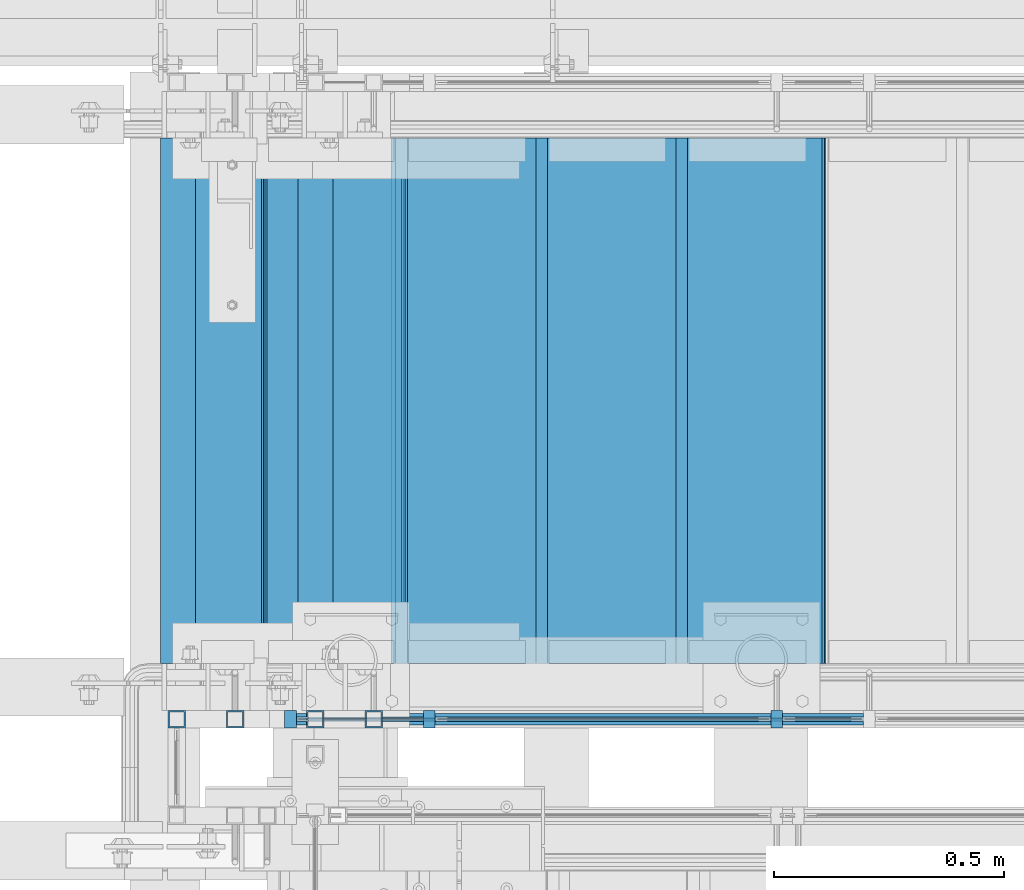
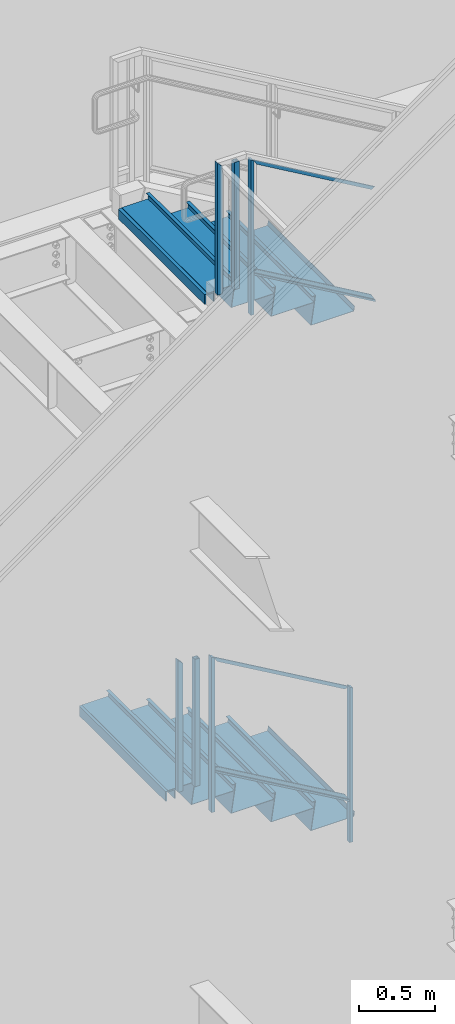
# One storey, part 791 of 1179: 15 beams, 9 members, 6 elements without a shape of their own.
"""IFC2X3 building model written with IfcOpenShell, lengths in millimetres."""

import ifcopenshell
import ifcopenshell.guid

model = None  # the IFC model being written
_history = None  # IfcOwnerHistory: only IFC2X3 demands one
_inside = {}  # id of a spatial element -> (the spatial element, [elements in it])
_under = {}  # id of a project, library or spatial element -> (it, [spatial elements below it])
_declared = {}  # id of a project -> (the project, [libraries it declares])
_typed = {}  # id of a type object -> (the type object, [elements of that type])
_made_of = {}  # id of a material, layer set ... -> (it, [elements and type objects made of it])


def new_model(schema):
    """Start an empty IFC model of exactly this schema.

    Asked for "IFC4X3", IfcOpenShell would pick the latest addendum, in which some entities
    have other attributes; the version numbers below select the first issue.
    IFC2X3 requires an IfcOwnerHistory on every rooted entity: one is made here for all.
    """
    global model, _history
    if schema == "IFC4X3":
        model = ifcopenshell.file(schema_version=(4, 3, 0, 0))
    else:
        model = ifcopenshell.file(schema=schema)
    _inside.clear()
    _under.clear()
    _declared.clear()
    _typed.clear()
    _made_of.clear()
    _history = None
    if model.schema == "IFC2X3":
        org = make("IfcOrganization", Name="unknown")
        user = make(
            "IfcPersonAndOrganization",
            ThePerson=make("IfcPerson", FamilyName="unknown"),
            TheOrganization=org,
        )
        app = make(
            "IfcApplication",
            ApplicationDeveloper=org,
            Version="unknown",
            ApplicationFullName="unknown",
            ApplicationIdentifier="unknown",
        )
        _history = make(
            "IfcOwnerHistory",
            OwningUser=user,
            OwningApplication=app,
            ChangeAction="ADDED",
            CreationDate=0,
        )
    return model


def make(cls, **values):
    """One entity of the class cls with the attributes given. An attribute that is None is left unset."""
    return model.create_entity(
        cls, **{name: value for name, value in values.items() if value is not None}
    )


def rooted(cls, **values):
    """An entity with a GlobalId (a new one), such as an element, a storey or a relation."""
    return make(cls, GlobalId=ifcopenshell.guid.new(), OwnerHistory=_history, **values)


def si_unit(unit_type, name, prefix=None):
    """IfcSIUnit, for example si_unit("LENGTHUNIT", "METRE", prefix="MILLI")."""
    return make("IfcSIUnit", UnitType=unit_type, Prefix=prefix, Name=name)


def assignment(units):
    """IfcUnitAssignment: the units of a project."""
    return None if units is None else make("IfcUnitAssignment", Units=units)


def point(xyz):
    """IfcCartesianPoint."""
    return None if xyz is None else make("IfcCartesianPoint", Coordinates=xyz)


def direction(xyz):
    """IfcDirection."""
    return None if xyz is None else make("IfcDirection", DirectionRatios=xyz)


def frame(location, z_axis=None, x_axis=None):
    """IfcAxis2Placement3D, a coordinate frame: its origin and axes. An axis left out is left unset."""
    return make(
        "IfcAxis2Placement3D",
        Location=point(location),
        Axis=direction(z_axis),
        RefDirection=direction(x_axis),
    )


def origin_with_axes():
    """The frame at (0, 0, 0) with the z axis (0, 0, 1) and the x axis (1, 0, 0) written out."""
    return frame((0.0, 0.0, 0.0), z_axis=(0.0, 0.0, 1.0), x_axis=(1.0, 0.0, 0.0))


def place(relative_to, where):
    """IfcLocalPlacement: puts the frame where relative to a parent placement (None: the world)."""
    return make(
        "IfcLocalPlacement", PlacementRelTo=relative_to, RelativePlacement=where
    )


def context(
    kind, dimensions, precision=None, world=None, true_north=None, identifier=None
):
    """IfcGeometricRepresentationContext, for example the 3D "Model" context."""
    return make(
        "IfcGeometricRepresentationContext",
        ContextIdentifier=identifier,
        ContextType=kind,
        CoordinateSpaceDimension=dimensions,
        Precision=precision,
        WorldCoordinateSystem=world,
        TrueNorth=true_north,
    )


def subcontext(parent, identifier, kind, view, scale=None):
    """IfcGeometricRepresentationSubContext, for example "Body" below "Model"."""
    return make(
        "IfcGeometricRepresentationSubContext",
        ContextIdentifier=identifier,
        ContextType=kind,
        ParentContext=parent,
        TargetScale=scale,
        TargetView=view,
    )


def project(units=None, contexts=None):
    """IfcProject with its units and contexts."""
    return rooted(
        "IfcProject",
        Name="project",
        RepresentationContexts=contexts,
        UnitsInContext=assignment(units),
    )


def spatial(cls, under=None, at=None, **own):
    """A site, building, storey or space (cls), placed at a placement, below another one or the project."""
    s = rooted(cls, ObjectPlacement=at, **own)
    if under is not None:
        _under.setdefault(under.id(), (under, []))[1].append(s)
    return s


def faces_of(points, faces, orient=None, outer=None):
    """IfcFace entities. A face is a list of loops; a loop is a list of indices into points, from 0.

    orient and outer hold one flag for each loop. By default every Orientation is true, the
    first loop of a face is its IfcFaceOuterBound and the others are IfcFaceBound.
    """
    made = []
    for i, loops in enumerate(faces):
        bounds = []
        for j, loop in enumerate(loops):
            is_outer = j == 0 if outer is None else outer[i][j]
            bounds.append(
                make(
                    "IfcFaceOuterBound" if is_outer else "IfcFaceBound",
                    Bound=make("IfcPolyLoop", Polygon=[points[k] for k in loop]),
                    Orientation=True if orient is None else orient[i][j],
                )
            )
        made.append(make("IfcFace", Bounds=bounds))
    return made


def faceted_brep(points, faces, orient=None, outer=None, voids=None):
    """IfcFacetedBrep: a solid bounded by flat faces; with voids (closed shells), ...WithVoids."""
    shared = [point(p) for p in points]
    hull = make("IfcClosedShell", CfsFaces=faces_of(shared, faces, orient, outer))
    if voids is None:
        return make("IfcFacetedBrep", Outer=hull)
    return make(
        "IfcFacetedBrepWithVoids",
        Outer=hull,
        Voids=[
            make(cls, CfsFaces=faces_of(shared, fs, o, b)) for cls, fs, o, b in voids
        ],
    )


def shape(context_of_items, identifier, shape_type, items):
    """IfcShapeRepresentation: the items that make up one representation, for example the "Body"."""
    return make(
        "IfcShapeRepresentation",
        ContextOfItems=context_of_items,
        RepresentationIdentifier=identifier,
        RepresentationType=shape_type,
        Items=items,
    )


def material(Name=None, Category=None):
    """IfcMaterial."""
    return make("IfcMaterial", Name=Name, Category=Category)


def made_of(thing, what):
    """Note that an element or type object is made of a material, layer set ...; save() writes the relation."""
    if what is not None:
        _made_of.setdefault(what.id(), (what, []))[1].append(thing)
    return thing


def type_object(cls, material=None, **own):
    """A type object (cls), such as IfcWallType, which elements share."""
    return made_of(rooted(cls, **own), material)


def element(
    cls,
    number,
    at=None,
    inside=None,
    cuts=None,
    type_object=None,
    material=None,
    context=None,
    identifier="Body",
    shape_type=None,
    held_by="IfcProductDefinitionShape",
    body=None,
    shapes=None,
    **own,
):
    """One element of the class cls, such as IfcWall. Its Tag is "e" and its number.

    at: its placement. inside: the storey or other place that contains it. cuts: it is an
    opening in that element (IfcRelVoidsElement). A single representation is given by context,
    identifier, shape_type and body (its items); several are given by shapes. held_by: the class
    of the entity that holds the representations. save() writes the other relations.
    """
    e = rooted(cls, Tag="e%d" % number, ObjectPlacement=at, **own)
    if body is not None:
        shapes = [shape(context, identifier, shape_type, body)]
    if shapes is not None:
        e.Representation = make(held_by, Representations=shapes)
    if inside is not None:
        _inside.setdefault(inside.id(), (inside, []))[1].append(e)
    if cuts is not None:
        rooted(
            "IfcRelVoidsElement", RelatingBuildingElement=cuts, RelatedOpeningElement=e
        )
    if type_object is not None:
        _typed.setdefault(type_object.id(), (type_object, []))[1].append(e)
    return made_of(e, material)


def aggregate(whole, parts):
    """IfcRelAggregates: a whole, such as a stair, and the parts it consists of."""
    return rooted("IfcRelAggregates", RelatingObject=whole, RelatedObjects=parts)


def save(model, path):
    """Write the relations noted so far, then the file.

    IfcRelAggregates (storeys below a building ...), IfcRelContainedInSpatialStructure (elements
    in a storey), IfcRelDefinesByType, IfcRelAssociatesMaterial and IfcRelDeclares: one each for
    every whole, place, type object, material and project.
    """
    for whole, parts in _under.values():
        aggregate(whole, parts)
    for where, things in _inside.values():
        rooted(
            "IfcRelContainedInSpatialStructure",
            RelatedElements=things,
            RelatingStructure=where,
        )
    for kind, things in _typed.values():
        rooted("IfcRelDefinesByType", RelatedObjects=things, RelatingType=kind)
    for what, things in _made_of.values():
        rooted("IfcRelAssociatesMaterial", RelatedObjects=things, RelatingMaterial=what)
    for by, libraries in _declared.values():
        rooted("IfcRelDeclares", RelatingContext=by, RelatedDefinitions=libraries)
    model.write(path)


model = new_model("IFC2X3")

# Units and contexts
model_context = context("Model", 3, precision=1e-05, world=origin_with_axes())
body_context = subcontext(model_context, "Body", "Model", "MODEL_VIEW")
ifc_project = project(units=[si_unit("LENGTHUNIT", "METRE", prefix="MILLI"), si_unit("AREAUNIT", "SQUARE_METRE"), si_unit("VOLUMEUNIT", "CUBIC_METRE"), si_unit("MASSUNIT", "GRAM", prefix="KILO"), si_unit("TIMEUNIT", "SECOND"), si_unit("PLANEANGLEUNIT", "RADIAN"), si_unit("SOLIDANGLEUNIT", "STERADIAN"), si_unit("THERMODYNAMICTEMPERATUREUNIT", "DEGREE_CELSIUS"), si_unit("LUMINOUSINTENSITYUNIT", "LUMEN")], contexts=[model_context])

# Site, building, storey
site_placement = place(None, origin_with_axes())
site = spatial("IfcSite", under=ifc_project, at=site_placement, CompositionType="ELEMENT")
building_placement = place(site_placement, origin_with_axes())
building = spatial("IfcBuilding", under=site, at=building_placement, Name="Undefined", CompositionType="ELEMENT")
storey_placement = place(building_placement, origin_with_axes())
storey = spatial("IfcBuildingStorey", under=building, at=storey_placement, Name="Undefined", CompositionType="ELEMENT", Elevation=0.0)

# Assembly, member
assembly_1_placement = place(storey_placement, origin_with_axes())
assembly_1 = element("IfcElementAssembly", 1, at=assembly_1_placement, inside=storey, Name="GUARDRAIL", AssemblyPlace="NOTDEFINED", PredefinedType="RIGID_FRAME")
ifc_material_1 = material(Name="STEEL/A36")
member_type_1 = type_object("IfcMemberType", PredefinedType="NOTDEFINED")
member_1_placement = place(assembly_1_placement, frame((20608.9249611471, 39681.150000778, 3388.43033673067), z_axis=(0.0, -1.0, 0.0), x_axis=(0.0, 0.0, 1.0)))
member_1 = element("IfcMember", 2, at=member_1_placement, type_object=member_type_1, material=ifc_material_1, Name="POST", context=body_context, shape_type="Brep", body=[
    faceted_brep([(0.0, 12.7000000000007, -19.0500000000029), (0.0, 12.7000000000007, 19.0500000000029), (1257.59245944594, 12.7000000000007, 19.0500000000029), (1257.59245944594, 12.7000000000007, -19.0500000000029), (0.0, -12.7000000000007, 19.0500000000029), (1242.88603583053, -12.7000000000007, 19.0500000000029), (0.0, -12.7000000000007, -19.0500000000029), (1242.88603583053, -12.7000000000007, -19.0500000000029)], [[[0, 1, 2, 3]], [[1, 4, 5, 2]], [[4, 6, 7, 5]], [[6, 0, 3, 7]], [[5, 7, 3, 2]], [[6, 4, 1, 0]]]),
])

assembly_2_placement = place(storey_placement, origin_with_axes())
assembly_2 = element("IfcElementAssembly", 3, at=assembly_2_placement, inside=storey, Name="GUARDRAIL", AssemblyPlace="NOTDEFINED", PredefinedType="RIGID_FRAME")
member_2_placement = place(assembly_2_placement, frame((19853.2749999269, 39681.1500007796, 7913.42903654841), z_axis=(0.0, -1.0, 0.0), x_axis=(0.0, 0.0, 1.0)))
member_2 = element("IfcMember", 4, at=member_2_placement, type_object=member_type_1, material=ifc_material_1, Name="POST", context=body_context, shape_type="Brep", body=[
    faceted_brep([(0.0, 12.7000000000007, -19.0500000000029), (0.0, 12.7000000000007, 19.0500000000029), (1257.9937907086, 12.7000000000007, 19.0500000000029), (1257.9937907086, 12.7000000000007, -19.0500000000029), (0.0, -12.7000000000007, 19.0500000000029), (1243.17712405909, -12.7000000000007, 19.0500000000029), (0.0, -12.7000000000007, -19.0500000000029), (1243.17712405909, -12.7000000000007, -19.0500000000029)], [[[0, 1, 2, 3]], [[1, 4, 5, 2]], [[4, 6, 7, 5]], [[6, 0, 3, 7]], [[5, 7, 3, 2]], [[6, 4, 1, 0]]]),
])

# Member
member_3_placement = place(assembly_1_placement, frame((19551.6499976895, 39681.1500007814, 4000.58519856457), z_axis=(0.0, -1.0, 0.0), x_axis=(0.0, 0.0, 1.0)))
member_3 = element("IfcMember", 5, at=member_3_placement, type_object=member_type_1, material=ifc_material_1, Name="POST", context=body_context, shape_type="Brep", body=[
    faceted_brep([(1242.88603583053, -12.7000000000007, 19.0500000000029), (1242.88603583053, -12.7000000000007, -19.0500000000029), (1257.59245944594, 12.7000000000007, -19.0500000000029), (1257.59245944594, 12.7000000000007, 19.0500000000029), (0.0, -12.7000000000007, -19.0500000000029), (0.0, -12.7000000000007, 19.0500000000029), (0.0, 12.7000000000007, 19.0500000000029), (0.0, 12.7000000000007, -19.0500000000029)], [[[0, 1, 2, 3]], [[4, 5, 6, 7]], [[7, 6, 3, 2]], [[4, 7, 2, 1]], [[5, 4, 1, 0]], [[6, 5, 0, 3]]]),
])

# Beam
ifc_material_2 = material(Name="STEEL/BUY-OUT")
beam_type_1 = type_object("IfcBeamType", PredefinedType="NOTDEFINED")
beam_1_placement = place(assembly_2_placement, frame((20344.5288575628, 39677.9751661883, 7996.27471618141), z_axis=(0.863778851027978, 0.0, -0.503871111016285), x_axis=(-0.503871111016286, 0.0, -0.863778851027978)))
beam_1 = element("IfcBeam", 6, at=beam_1_placement, type_object=beam_type_1, material=ifc_material_2, Name="U-EDGE", context=body_context, shape_type="Brep", body=[
    faceted_brep([(5.85307134315372e-07, 7.9375000095315, 493.146654191507), (25.4000002943358, 7.93750001315493, 537.368999999748), (25.4000002935682, 7.93749998683779, -537.369000000126), (5.89814590057358e-07, 7.93749998989369, -522.778334533057), (5.85307134315372e-07, 4.76250000952859, 493.146654191507), (5.89814590057358e-07, 4.76249998989806, -522.778334533057), (22.2250002943329, 4.76250001302105, 531.841205669258), (22.2250002935725, 4.76249998688581, -535.543713894371), (22.2250003046174, 1.58750000000146, 531.841205687164), (22.2250002832152, 1.58750000000146, -535.543713888419), (3.49245965480804e-10, 1.58750000000146, 493.146653173078), (-3.78349795937538e-10, 1.58750000000146, -522.778334194069), (3.49245965480804e-10, -1.58750000000146, 493.146653173078), (-3.78349795937538e-10, -1.58750000000146, -522.778334194069), (25.4000003047295, -1.58750000000146, 537.368999999901), (25.4000002831781, -1.58750000000146, -537.36899999997)], [[[0, 1, 2, 3]], [[4, 0, 3, 5]], [[6, 4, 5, 7]], [[8, 6, 7, 9]], [[10, 8, 9, 11]], [[12, 10, 11, 13]], [[14, 12, 13, 15]], [[11, 9, 7, 5, 3, 2, 15, 13]], [[1, 14, 15, 2]], [[0, 4, 6, 8, 10, 12, 14, 1]]]),
])

beam_2_placement = place(assembly_2_placement, frame((20318.932180216, 39677.9751661883, 8861.25559265299), z_axis=(0.863778851027978, 0.0, -0.503871111016285), x_axis=(0.503871025088838, 0.0, 0.863778901152328)))
beam_2 = element("IfcBeam", 7, at=beam_2_placement, type_object=beam_type_1, material=ifc_material_2, Name="U-EDGE", context=body_context, shape_type="Brep", body=[
    faceted_brep([(8.44738679006696e-09, -4.76249999999709, -493.146660186705), (8.44738679006696e-09, -7.9375, -493.146660186705), (8.65475158207119e-09, -7.9375, 522.779993519576), (8.65475158207119e-09, -4.76249999999709, 522.779993519576), (22.2250000040658, -4.76249999999709, -531.84120750705), (22.2250000042877, -4.76249999999709, 535.54537418879), (22.2250000040658, -1.58750000000146, -531.84120750705), (22.2250000042877, -1.58750000000146, 535.54537418879), (-1.01863406598568e-10, -1.58750000000146, -493.146660171822), (1.09139364212751e-10, -1.58750000000146, 522.779993514665), (-1.01863406598568e-10, 1.58750000000146, -493.146660171822), (1.09139364212751e-10, 1.58750000000146, 522.779993514665), (25.4000000040614, 1.58750000000146, -537.368999999624), (25.400000004287, 1.58750000000146, 537.368999999613), (25.4000000040614, -7.9375, -537.368999999624), (25.400000004287, -7.9375, 537.368999999613)], [[[0, 1, 2, 3]], [[4, 0, 3, 5]], [[6, 4, 5, 7]], [[8, 6, 7, 9]], [[10, 8, 9, 11]], [[12, 10, 11, 13]], [[14, 12, 13, 15]], [[11, 9, 7, 5, 3, 2, 15, 13]], [[1, 14, 15, 2]], [[0, 4, 6, 8, 10, 12, 14, 1]]]),
])

beam_3_placement = place(assembly_1_placement, frame((20092.8623203506, 39677.9751661867, 4055.74095164783), z_axis=(0.86540914081268, 0.0, -0.501065882891521), x_axis=(-0.501065882891527, 0.0, -0.865409140812677)))
beam_3 = element("IfcBeam", 8, at=beam_3_placement, type_object=beam_type_1, material=ifc_material_2, Name="U-EDGE", context=body_context, shape_type="Brep", body=[
    faceted_brep([(-2.17914930544794e-09, 1.58750000000146, -579.8750616161), (-2.17914930544794e-09, -1.58750000000146, -579.8750616161), (2.06819095183164e-09, -1.58750000000146, 550.462303003866), (2.06819095183164e-09, 1.58750000000146, 550.462303003866), (22.2250000220702, 1.58750000000146, -592.688577145202), (22.225000051898, 1.58750000000146, 589.01191290709), (22.225000034794, 4.76249998386629, -592.688577152541), (22.2250000392505, 4.7625000160333, 589.011912885151), (7.50696926843375e-08, 4.76249998754065, -579.875061660634), (7.28450686438009e-08, 4.7625000118278, 550.462303126626), (7.50696926843375e-08, 7.93749998753628, -579.875061660634), (7.28450686438009e-08, 7.93750001182343, 550.462303126626), (25.4000000347896, 7.93749998381099, -594.518999999977), (25.4000000343149, 7.9375, 594.519), (25.4000000220258, -1.58750000000146, -594.518999999807), (25.4000000343149, -1.58750000000146, 594.519)], [[[0, 1, 2, 3]], [[4, 0, 3, 5]], [[6, 4, 5, 7]], [[8, 6, 7, 9]], [[10, 8, 9, 11]], [[12, 10, 11, 13]], [[14, 12, 13, 15]], [[11, 9, 7, 5, 3, 2, 15, 13]], [[1, 14, 15, 2]], [[0, 4, 6, 8, 10, 12, 14, 1]]]),
])

beam_4_placement = place(assembly_1_placement, frame((20067.408210734, 39677.9751661867, 4921.4162257045), z_axis=(0.86540914081268, 0.0, -0.501065882891521), x_axis=(0.501065882891522, 0.0, 0.865409140812679)))
beam_4 = element("IfcBeam", 9, at=beam_4_placement, type_object=beam_type_1, material=ifc_material_2, Name="U-EDGE", context=body_context, shape_type="Brep", body=[
    faceted_brep([(-5.08043740410358e-09, -4.76250001176231, -550.462297073285), (-5.08043740410358e-09, -7.93750001176522, -550.462297073285), (2.06819095183164e-09, -7.93749998760177, 579.875144306196), (2.06819095183164e-09, -4.76249998760613, 579.875144306196), (22.2249999989635, -4.76250001590233, -589.011912123857), (22.2249999997566, -4.76249998399726, 592.68851804268), (22.2250000115582, -1.58750000000146, -589.011912145696), (22.2249999870892, -1.58750000000146, 592.68851803538), (-3.47426976077259e-10, -1.58750000000146, -550.462297081494), (3.69254848919809e-10, -1.58750000000146, 579.875144305217), (-3.47426976077259e-10, 1.58750000000146, -550.462297081494), (3.69254848919809e-10, 1.58750000000146, 579.875144305217), (25.4000001784334, 1.58750000000146, -594.51900000087), (25.3999999489688, 1.58750000000146, 594.519), (25.4000002532193, -7.93749990531796, -594.51900000187), (25.3999999489688, -7.9375, 594.519)], [[[0, 1, 2, 3]], [[4, 0, 3, 5]], [[6, 4, 5, 7]], [[8, 6, 7, 9]], [[10, 8, 9, 11]], [[12, 10, 11, 13]], [[14, 12, 13, 15]], [[11, 9, 7, 5, 3, 2, 15, 13]], [[1, 14, 15, 2]], [[0, 4, 6, 8, 10, 12, 14, 1]]]),
])

# Member
ifc_material_3 = material()
member_type_2 = type_object("IfcMemberType", Name="HSS1-1/2X1-1/2X1/8", PredefinedType="NOTDEFINED")
member_4_placement = place(assembly_1_placement, frame((19430.9999984545, 39681.1500007814, 4248.15), z_axis=(-1.0, 0.0, 0.0), x_axis=(0.0, 0.0, 1.0)))
member_4 = element("IfcMember", 10, at=member_4_placement, type_object=member_type_2, material=ifc_material_3, Name="POST", ObjectType="HSS1-1/2X1-1/2X1/8", context=body_context, shape_type="Brep", body=[
    faceted_brep([(1035.05, -19.050000003459, 19.0499992350015), (1035.05, -19.0499992350015, -19.0499992350015), (1035.05, 19.0499992350015, -19.0499992350015), (1035.05, 19.0499992350015, 19.0499992350015), (1035.05, -15.874999282998, 15.8749992830017), (1035.05, 15.874999282998, 15.8749992830017), (1035.05, 15.874999282998, -15.8749992830017), (1035.05, -15.874999282998, -15.8749992830017), (6.35000000000014, 19.0499992350015, 19.0499992350015), (6.35000000000014, -19.0499992350015, 19.0499992350015), (6.35000000000014, -19.0499992350015, -19.0499992350015), (6.35000000000014, 19.0499992350015, -19.0499992350015), (6.35000000000014, 15.874999282998, 15.8749992830017), (6.35000000000014, -15.874999282998, 15.8749992830017), (6.35000000000014, -15.874999282998, -15.8749992830017), (6.35000000000014, 15.874999282998, -15.8749992830017)], [[[0, 1, 2, 3], [4, 5, 6, 7]], [[8, 9, 0, 3]], [[10, 11, 2, 1]], [[9, 10, 1, 0]], [[11, 8, 3, 2]], [[10, 9, 8, 11], [12, 13, 14, 15]], [[14, 13, 4, 7]], [[15, 14, 7, 6]], [[12, 15, 6, 5]], [[13, 12, 5, 4]]]),
])

member_5_placement = place(assembly_2_placement, frame((19605.6250024101, 39681.1500007796, 8159.7499999606), z_axis=(-1.0, 0.0, 0.0), x_axis=(0.0, 0.0, 1.0)))
member_5 = element("IfcMember", 11, at=member_5_placement, type_object=member_type_2, material=ifc_material_3, Name="POST", ObjectType="HSS1-1/2X1-1/2X1/8", context=body_context, shape_type="Brep", body=[
    faceted_brep([(6.35000000000014, 15.874999282998, -15.8749992830017), (6.35000000000014, -15.874999282998, -15.8749992830017), (1038.22500111138, -15.874999282998, -15.8749992816192), (1038.22500111138, 15.874999282998, -15.8749992816192), (6.35000000000014, -15.874999282998, 15.8749992830017), (1069.97499995772, -15.874999282998, 15.8749992844241), (6.35000000000014, 15.874999282998, 15.8749992830017), (1069.97499995772, 15.874999282998, 15.8749992844241), (6.35000000000014, 19.0499992350015, -19.0499992350015), (6.35000000000014, 19.0499992350015, 19.0499992350015), (1073.14999993776, 19.0499992350015, 19.0499992364275), (1035.05, 19.0499992350015, -19.0499992350015), (6.35000000000014, -19.0499992350015, 19.0499992350015), (1073.14999993776, -19.0499992350015, 19.0499992364275), (6.35000000000014, -19.0499992350015, -19.0499992350015), (1035.05, -19.0499992350015, -19.0499992350015)], [[[0, 1, 2, 3]], [[1, 4, 5, 2]], [[4, 6, 7, 5]], [[6, 0, 3, 7]], [[8, 9, 10, 11]], [[9, 12, 13, 10]], [[12, 14, 15, 13]], [[14, 8, 11, 15]], [[13, 15, 11, 10], [5, 7, 3, 2]], [[14, 12, 9, 8], [6, 4, 1, 0]]]),
])

member_6_placement = place(assembly_2_placement, frame((19732.6249999269, 39681.1500007796, 8159.75), z_axis=(-1.0, 0.0, 0.0), x_axis=(0.0, 0.0, 1.0)))
member_6 = element("IfcMember", 12, at=member_6_placement, type_object=member_type_2, material=ifc_material_3, Name="POST", ObjectType="HSS1-1/2X1-1/2X1/8", context=body_context, shape_type="Brep", body=[
    faceted_brep([(6.35000000000014, -19.0499992350015, -19.0499992350015), (6.35000000000014, 19.0499992350015, -19.0499992350015), (1035.05, 19.0499992350015, -19.0499992350015), (1035.05, -19.0499992350015, -19.0499992350015), (6.35000000000014, -19.0499992350015, 19.0499992350015), (1035.05, -19.050000003459, 19.0499992350015), (6.35000000000014, 19.0499992350015, 19.0499992350015), (1035.05, 19.0499992350015, 19.0499992350015), (6.35000000000014, -15.874999282998, -15.8749992830017), (6.35000000000014, -15.874999282998, 15.8749992830017), (1035.05, -15.874999282998, 15.8749992830017), (1035.05, -15.874999282998, -15.8749992830017), (6.35000000000014, 15.874999282998, 15.8749992830017), (1035.05, 15.874999282998, 15.8749992830017), (6.35000000000014, 15.874999282998, -15.8749992830017), (1035.05, 15.874999282998, -15.8749992830017)], [[[0, 1, 2, 3]], [[4, 0, 3, 5]], [[6, 4, 5, 7]], [[1, 6, 7, 2]], [[8, 9, 10, 11]], [[9, 12, 13, 10]], [[12, 14, 15, 13]], [[5, 3, 2, 7], [10, 13, 15, 11]], [[14, 8, 11, 15]], [[0, 4, 6, 1], [12, 9, 8, 14]]]),
])

member_7_placement = place(assembly_1_placement, frame((19303.9999999845, 39681.1500007814, 4248.15), z_axis=(-1.0, 0.0, 0.0), x_axis=(0.0, 0.0, 1.0)))
member_7 = element("IfcMember", 13, at=member_7_placement, type_object=member_type_2, material=ifc_material_3, Name="POST", ObjectType="HSS1-1/2X1-1/2X1/8", context=body_context, shape_type="Brep", body=[
    faceted_brep([(6.35000000000014, 15.874999282998, -15.8749992830017), (6.35000000000014, -15.874999282998, -15.8749992830017), (1038.22500111138, -15.874999282998, -15.8749992816192), (1038.22500111138, 15.874999282998, -15.8749992816192), (6.35000000000014, -15.874999282998, 15.8749992830017), (1069.97499995772, -15.874999282998, 15.8749992844241), (6.35000000000014, 15.874999282998, 15.8749992830017), (1069.97499995772, 15.874999282998, 15.8749992844241), (6.35000000000014, 19.0499992350015, -19.0499992350015), (6.35000000000014, 19.0499992350015, 19.0499992350015), (1073.14999993776, 19.0499992350015, 19.0499992364275), (1035.05, 19.0499992350015, -19.0499992350015), (6.35000000000014, -19.0499992350015, 19.0499992350015), (1073.14999993776, -19.0499992350015, 19.0499992364275), (6.35000000000014, -19.0499992350015, -19.0499992350015), (1035.05, -19.0499992350015, -19.0499992350015)], [[[0, 1, 2, 3]], [[1, 4, 5, 2]], [[4, 6, 7, 5]], [[6, 0, 3, 7]], [[8, 9, 10, 11]], [[9, 12, 13, 10]], [[12, 14, 15, 13]], [[14, 8, 11, 15]], [[13, 15, 11, 10], [5, 7, 3, 2]], [[14, 12, 9, 8], [6, 4, 1, 0]]]),
])

member_type_3 = type_object("IfcMemberType", PredefinedType="NOTDEFINED")
member_8_placement = place(assembly_2_placement, frame((19853.2749999281, 39681.1500007796, 8244.2428589148), z_axis=(0.0, -1.0, 0.0), x_axis=(0.863778851027978, 0.0, -0.503871111016285)))
member_8 = element("IfcMember", 14, at=member_8_placement, type_object=member_type_3, material=ifc_material_1, Name="BOTTOM_RAIL", context=body_context, shape_type="Brep", body=[
    faceted_brep([(1096.61501763624, -6.34999999974752, 12.6999999999971), (1096.61501763624, -6.34999999974752, -12.6999999999971), (1089.20668431148, 6.35000000024229, -12.6999999999971), (1089.20668431148, 6.35000000024229, 12.6999999999971), (18.4070032121654, -6.34999999999127, -12.6999999999971), (18.4070032121654, -6.34999999999127, 12.6999999999971), (10.9986698874163, 6.34999999999854, 12.6999999999971), (10.9986698874163, 6.34999999999854, -12.6999999999971)], [[[0, 1, 2, 3]], [[4, 5, 6, 7]], [[6, 5, 0, 3]], [[7, 6, 3, 2]], [[4, 7, 2, 1]], [[5, 4, 1, 0]]]),
])

aggregate(assembly_2, [beam_1, beam_2, member_8, member_5, member_2, member_6])

member_9_placement = place(assembly_1_placement, frame((19551.6499976848, 39681.150000778, 4330.77584080213), z_axis=(0.0, -1.0, 0.0), x_axis=(0.86540914081268, 0.0, -0.501065882891521)))
member_9 = element("IfcMember", 15, at=member_9_placement, type_object=member_type_3, material=ifc_material_1, Name="BOTTOM_RAIL", context=body_context, shape_type="Brep", body=[
    faceted_brep([(10.998533752896, 6.34999999999854, -12.6999999999971), (10.998533752896, 6.34999999999854, 12.6999999999971), (1203.35358848741, 6.35000000053878, 12.6999999999971), (1203.35358848741, 6.35000000053878, -12.6999999999971), (18.3517455606161, -6.34999999998945, 12.6999999999971), (1210.70680029513, -6.34999999944921, 12.6999999999971), (18.3517455606161, -6.34999999998945, -12.6999999999971), (1210.70680029513, -6.34999999944921, -12.6999999999971)], [[[0, 1, 2, 3]], [[1, 4, 5, 2]], [[4, 6, 7, 5]], [[6, 0, 3, 7]], [[5, 7, 3, 2]], [[6, 4, 1, 0]]]),
])

aggregate(assembly_1, [beam_3, beam_4, member_9, member_1, member_4, member_7, member_3])

# Assembly, beam
assembly_3_placement = place(storey_placement, origin_with_axes())
assembly_3 = element("IfcElementAssembly", 16, at=assembly_3_placement, inside=storey, Name="STAIR", AssemblyPlace="NOTDEFINED", PredefinedType="RIGID_FRAME")
beam_type_2 = type_object("IfcBeamType", PredefinedType="NOTDEFINED")
beam_5_placement = place(assembly_3_placement, frame((19592.9244395215, 40373.3000001377, 8094.96), z_axis=(0.0, 1.0, 0.0), x_axis=(1.0, 0.0, 0.0)))
beam_5 = element("IfcBeam", 17, at=beam_5_placement, type_object=beam_type_2, material=ifc_material_1, Name="TREAD", context=body_context, shape_type="Brep", body=[
    faceted_brep([(0.0, -1.28999999999996, -571.5), (0.0, -1.28999999999996, 571.5), (0.0, 1.28999999999996, 571.5), (0.0, 1.28999999999996, -571.5), (202.497812979535, 1.28999999999996, 571.5), (202.497812979535, 1.28999999999996, -571.5), (200.25913877938, -1.28999999999996, -571.5), (200.25913877938, -1.28999999999996, 571.5), (208.182857588272, -38.6380216407206, 571.5), (208.182857588272, -38.6380216407206, -571.5), (205.628618379884, -39.0017001613278, 571.5), (205.628618379884, -39.0017001613278, -571.5)], [[[0, 1, 2, 3]], [[3, 2, 4, 5]], [[1, 0, 6, 7]], [[5, 4, 8, 9]], [[4, 2, 1, 7, 10, 8]], [[7, 6, 11, 10]], [[6, 0, 3, 5, 9, 11]], [[10, 11, 9, 8]]]),
])

assembly_4_placement = place(storey_placement, origin_with_axes())
assembly_4 = element("IfcElementAssembly", 18, at=assembly_4_placement, inside=storey, Name="BEAM", AssemblyPlace="NOTDEFINED", PredefinedType="RIGID_FRAME")
beam_type_3 = type_object("IfcBeamType", Name="HSS6X3X3/8", PredefinedType="NOTDEFINED")
beam_6_placement = place(assembly_4_placement, frame((19605.625, 39801.7995000474, 8017.46999940807), z_axis=(0.0, 0.0, 1.0), x_axis=(0.0, 1.0, 0.0)))
beam_6 = element("IfcBeam", 19, at=beam_6_placement, type_object=beam_type_3, material=ifc_material_3, Name="BEAM", ObjectType="HSS6X3X3/8", context=body_context, shape_type="Brep", body=[
    faceted_brep([(0.0, -28.5750000000007, 66.6750000000002), (0.0, 28.5750000000007, 66.6750000000002), (1143.00050009481, 28.5750000000007, 66.6750000000002), (1143.00050009481, -28.5750000000007, 66.6750000000002), (0.0, 28.5750000000007, -3.769999408074), (1143.00050009481, 28.5750000000007, -3.769999408074), (0.0, 38.0999999999985, -3.769999408074), (1143.00050009481, 38.0999999999985, -3.769999408074), (0.0, 38.0999999999985, 76.1999999999998), (1143.00050009481, 38.0999999999985, 76.1999999999998), (0.0, -38.0999999999985, 76.1999999999998), (1143.00050009481, -38.0999999999985, 76.1999999999998), (1143.00050009481, -38.0999999999985, -3.769999408074), (1143.00050009481, -28.5750000000007, -3.769999408074), (0.0, -28.5750000000007, -3.769999408074), (0.0, -38.0999999999985, -3.769999408074)], [[[0, 1, 2, 3]], [[2, 1, 4, 5]], [[6, 7, 5, 4]], [[8, 9, 7, 6]], [[8, 10, 11, 9]], [[3, 2, 5, 7, 9, 11, 12, 13]], [[0, 3, 13, 14]], [[10, 8, 6, 4, 1, 0, 14, 15]], [[11, 10, 15, 12]], [[14, 13, 12, 15]]]),
])
aggregate(assembly_4, [beam_6])

assembly_5_placement = place(storey_placement, origin_with_axes())
assembly_5 = element("IfcElementAssembly", 20, at=assembly_5_placement, inside=storey, Name="BEAM", AssemblyPlace="NOTDEFINED", PredefinedType="RIGID_FRAME")
beam_7_placement = place(assembly_5_placement, frame((19307.175, 39801.7995000474, 4105.86999940896), z_axis=(0.0, 0.0, 1.0), x_axis=(0.0, 1.0, 0.0)))
beam_7 = element("IfcBeam", 21, at=beam_7_placement, type_object=beam_type_3, material=ifc_material_3, Name="BEAM", ObjectType="HSS6X3X3/8", context=body_context, shape_type="Brep", body=[
    faceted_brep([(0.0, -28.5750000000007, 66.6750000000002), (0.0, 28.5750000000007, 66.6750000000002), (1143.00050009481, 28.5750000000007, 66.6750000000002), (1143.00050009481, -28.5750000000007, 66.6750000000002), (0.0, 28.5750000000007, -3.769999408074), (1143.00050009481, 28.5750000000007, -3.769999408074), (0.0, 38.0999999999985, -3.769999408074), (1143.00050009481, 38.0999999999985, -3.769999408074), (0.0, 38.0999999999985, 76.1999999999998), (1143.00050009481, 38.0999999999985, 76.1999999999998), (0.0, -38.0999999999985, 76.1999999999998), (1143.00050009481, -38.0999999999985, 76.1999999999998), (1143.00050009481, -38.0999999999985, -3.769999408074), (1143.00050009481, -28.5750000000007, -3.769999408074), (0.0, -28.5750000000007, -3.769999408074), (0.0, -38.0999999999985, -3.769999408074)], [[[0, 1, 2, 3]], [[2, 1, 4, 5]], [[6, 7, 5, 4]], [[8, 9, 7, 6]], [[8, 10, 11, 9]], [[3, 2, 5, 7, 9, 11, 12, 13]], [[0, 3, 13, 14]], [[10, 8, 6, 4, 1, 0, 14, 15]], [[11, 10, 15, 12]], [[14, 13, 12, 15]]]),
])
aggregate(assembly_5, [beam_7])

assembly_6_placement = place(storey_placement, origin_with_axes())
assembly_6 = element("IfcElementAssembly", 22, at=assembly_6_placement, inside=storey, Name="STAIR", AssemblyPlace="NOTDEFINED", PredefinedType="RIGID_FRAME")
beam_type_4 = type_object("IfcBeamType", PredefinedType="NOTDEFINED")
beam_8_placement = place(assembly_6_placement, frame((19287.7531032031, 40373.3000001377, 4183.36000029555), z_axis=(0.0, 1.0, 0.0), x_axis=(1.0, 0.0, 0.0)))
beam_8 = element("IfcBeam", 23, at=beam_8_placement, type_object=beam_type_4, material=ifc_material_1, Name="TREAD", context=body_context, shape_type="Brep", body=[
    faceted_brep([(0.0, -1.28999999999996, -571.5), (0.0, -1.28999999999996, 571.5), (0.0, 1.28999999999996, 571.5), (0.0, 1.28999999999996, -571.5), (202.807433045477, 1.28999999999996, 571.5), (202.807433045477, 1.28999999999996, -571.5), (200.572181644777, -1.28999999999996, -571.5), (200.572181644777, -1.28999999999996, 571.5), (208.182303806017, -36.0541541278362, 571.5), (208.182303806017, -36.0541541278362, -571.5), (205.628618379873, -36.4217010558405, 571.5), (205.628618379873, -36.4217010558405, -571.5)], [[[0, 1, 2, 3]], [[3, 2, 4, 5]], [[1, 0, 6, 7]], [[5, 4, 8, 9]], [[4, 2, 1, 7, 10, 8]], [[7, 6, 11, 10]], [[6, 0, 3, 5, 9, 11]], [[10, 11, 9, 8]]]),
])

# Beam
beam_type_5 = type_object("IfcBeamType", PredefinedType="NOTDEFINED")
beam_9_placement = place(assembly_3_placement, frame((19780.2500028009, 40373.3000000029, 8145.76000000931), z_axis=(0.0, 1.0, 0.0), x_axis=(1.0, 0.0, 0.0)))
beam_9 = element("IfcBeam", 24, at=beam_9_placement, type_object=beam_type_5, material=ifc_material_1, Name="TREAD", context=body_context, shape_type="Brep", body=[
    faceted_brep([(0.0, -1.28999999999996, -571.5), (0.0, -1.28999999999996, 571.5), (0.0, 1.28999999999996, 571.5), (0.0, 1.28999999999996, -571.5), (22.4252350064853, 1.28999999999996, 571.5), (22.4252350064853, 1.28999999999996, -571.5), (25.4000000000015, -1.28999999999996, -571.5), (25.4000000000015, -1.28999999999996, 571.5), (-10.2319078506589, 229.89, 571.5), (-10.2319078506589, 229.89, -571.5), (-7.25714285714275, 227.31, -571.5), (-7.25714285714275, 227.31, 571.5), (319.968697988821, 229.89, 571.5), (319.968697988821, 229.89, -571.5), (317.731075852447, 227.31, -571.5), (317.731075852447, 227.31, 571.5), (325.673299218732, 189.957791390602, 571.5), (325.673299218732, 189.957791390602, -571.5), (323.119229525088, 189.592924291511, 571.5), (323.119229525088, 189.592924291511, -571.5)], [[[0, 1, 2, 3]], [[3, 2, 4, 5]], [[1, 0, 6, 7]], [[5, 4, 8, 9]], [[7, 6, 10, 11]], [[9, 8, 12, 13]], [[11, 10, 14, 15]], [[13, 12, 16, 17]], [[12, 8, 4, 2, 1, 7, 11, 15, 18, 16]], [[15, 14, 19, 18]], [[14, 10, 6, 0, 3, 5, 9, 13, 17, 19]], [[18, 19, 17, 16]]]),
])

beam_10_placement = place(assembly_3_placement, frame((20085.0500025488, 40373.3000000029, 7967.96000000931), z_axis=(0.0, 1.0, 0.0), x_axis=(1.0, 0.0, 0.0)))
beam_10 = element("IfcBeam", 25, at=beam_10_placement, type_object=beam_type_5, material=ifc_material_1, Name="TREAD", context=body_context, shape_type="Brep", body=[
    faceted_brep([(0.0, -1.28999999999996, -571.5), (0.0, -1.28999999999996, 571.5), (0.0, 1.28999999999996, 571.5), (0.0, 1.28999999999996, -571.5), (22.4252350064853, 1.28999999999996, 571.5), (22.4252350064853, 1.28999999999996, -571.5), (25.4000000000015, -1.28999999999996, -571.5), (25.4000000000015, -1.28999999999996, 571.5), (-10.2319078506589, 229.89, 571.5), (-10.2319078506589, 229.89, -571.5), (-7.25714285714275, 227.31, -571.5), (-7.25714285714275, 227.31, 571.5), (319.968697988821, 229.89, 571.5), (319.968697988821, 229.89, -571.5), (317.731075852447, 227.31, -571.5), (317.731075852447, 227.31, 571.5), (325.673299218732, 189.957791390602, 571.5), (325.673299218732, 189.957791390602, -571.5), (323.119229525088, 189.592924291511, 571.5), (323.119229525088, 189.592924291511, -571.5)], [[[0, 1, 2, 3]], [[3, 2, 4, 5]], [[1, 0, 6, 7]], [[5, 4, 8, 9]], [[7, 6, 10, 11]], [[9, 8, 12, 13]], [[11, 10, 14, 15]], [[13, 12, 16, 17]], [[12, 8, 4, 2, 1, 7, 11, 15, 18, 16]], [[15, 14, 19, 18]], [[14, 10, 6, 0, 3, 5, 9, 13, 17, 19]], [[18, 19, 17, 16]]]),
])

beam_11_placement = place(assembly_3_placement, frame((20389.8500022968, 40373.3000000029, 7790.1600000093), z_axis=(0.0, 1.0, 0.0), x_axis=(1.0, 0.0, 0.0)))
beam_11 = element("IfcBeam", 26, at=beam_11_placement, type_object=beam_type_5, material=ifc_material_1, Name="TREAD", context=body_context, shape_type="Brep", body=[
    faceted_brep([(0.0, -1.28999999999996, -571.5), (0.0, -1.28999999999996, 571.5), (0.0, 1.28999999999996, 571.5), (0.0, 1.28999999999996, -571.5), (22.4252350064853, 1.28999999999996, 571.5), (22.4252350064853, 1.28999999999996, -571.5), (25.4000000000015, -1.28999999999996, -571.5), (25.4000000000015, -1.28999999999996, 571.5), (-10.2319078506589, 229.89, 571.5), (-10.2319078506589, 229.89, -571.5), (-7.25714285714275, 227.31, -571.5), (-7.25714285714275, 227.31, 571.5), (319.968697988821, 229.89, 571.5), (319.968697988821, 229.89, -571.5), (317.731075852447, 227.31, -571.5), (317.731075852447, 227.31, 571.5), (325.673299218732, 189.957791390602, 571.5), (325.673299218732, 189.957791390602, -571.5), (323.119229525088, 189.592924291511, 571.5), (323.119229525088, 189.592924291511, -571.5)], [[[0, 1, 2, 3]], [[3, 2, 4, 5]], [[1, 0, 6, 7]], [[5, 4, 8, 9]], [[7, 6, 10, 11]], [[9, 8, 12, 13]], [[11, 10, 14, 15]], [[13, 12, 16, 17]], [[12, 8, 4, 2, 1, 7, 11, 15, 18, 16]], [[15, 14, 19, 18]], [[14, 10, 6, 0, 3, 5, 9, 13, 17, 19]], [[18, 19, 17, 16]]]),
])

aggregate(assembly_3, [beam_5, beam_9, beam_10, beam_11])

beam_12_placement = place(assembly_6_placement, frame((19780.2500004063, 40373.3000001154, 4057.68291612078), z_axis=(0.0, 1.0, 0.0), x_axis=(1.0, 0.0, 0.0)))
beam_12 = element("IfcBeam", 27, at=beam_12_placement, type_object=beam_type_5, material=ifc_material_1, Name="TREAD", context=body_context, shape_type="Brep", body=[
    faceted_brep([(0.0, -1.28999999999996, -571.5), (0.0, -1.28999999999996, 571.5), (0.0, 1.28999999999996, 571.5), (0.0, 1.28999999999996, -571.5), (22.4220799334253, 1.28999999999996, 571.5), (22.4220799334253, 1.28999999999996, -571.5), (25.4000000000015, -1.28999999999996, -571.5), (25.4000000000015, -1.28999999999996, 571.5), (-10.2894642965184, 228.56708328371, 571.5), (-10.2894642965184, 228.56708328371, -571.5), (-7.31154422994223, 225.98708328371, -571.5), (-7.31154422994223, 225.98708328371, 571.5), (319.911141878769, 228.56708328371, 571.5), (319.911141878769, 228.56708328371, -571.5), (317.675890478069, 225.98708328371, -571.5), (317.675890478069, 225.98708328371, 571.5), (325.657303794516, 188.643229151176, 571.5), (325.657303794516, 188.643229151176, -571.5), (323.103618368372, 188.27568222317, 571.5), (323.103618368372, 188.27568222317, -571.5)], [[[0, 1, 2, 3]], [[3, 2, 4, 5]], [[1, 0, 6, 7]], [[5, 4, 8, 9]], [[7, 6, 10, 11]], [[9, 8, 12, 13]], [[11, 10, 14, 15]], [[13, 12, 16, 17]], [[12, 8, 4, 2, 1, 7, 11, 15, 18, 16]], [[15, 14, 19, 18]], [[14, 10, 6, 0, 3, 5, 9, 13, 17, 19]], [[18, 19, 17, 16]]]),
])

beam_13_placement = place(assembly_6_placement, frame((20085.0500003989, 40373.3000001154, 3881.20583283707), z_axis=(0.0, 1.0, 0.0), x_axis=(1.0, 0.0, 0.0)))
beam_13 = element("IfcBeam", 28, at=beam_13_placement, type_object=beam_type_5, material=ifc_material_1, Name="TREAD", context=body_context, shape_type="Brep", body=[
    faceted_brep([(0.0, -1.28999999999996, -571.5), (0.0, -1.28999999999996, 571.5), (0.0, 1.28999999999996, 571.5), (0.0, 1.28999999999996, -571.5), (22.4220799334253, 1.28999999999996, 571.5), (22.4220799334253, 1.28999999999996, -571.5), (25.4000000000015, -1.28999999999996, -571.5), (25.4000000000015, -1.28999999999996, 571.5), (-10.2894642965184, 228.56708328371, 571.5), (-10.2894642965184, 228.56708328371, -571.5), (-7.31154422994223, 225.98708328371, -571.5), (-7.31154422994223, 225.98708328371, 571.5), (319.911141878769, 228.56708328371, 571.5), (319.911141878769, 228.56708328371, -571.5), (317.675890478069, 225.98708328371, -571.5), (317.675890478069, 225.98708328371, 571.5), (325.657303794516, 188.643229151176, 571.5), (325.657303794516, 188.643229151176, -571.5), (323.103618368372, 188.27568222317, 571.5), (323.103618368372, 188.27568222317, -571.5)], [[[0, 1, 2, 3]], [[3, 2, 4, 5]], [[1, 0, 6, 7]], [[5, 4, 8, 9]], [[7, 6, 10, 11]], [[9, 8, 12, 13]], [[11, 10, 14, 15]], [[13, 12, 16, 17]], [[12, 8, 4, 2, 1, 7, 11, 15, 18, 16]], [[15, 14, 19, 18]], [[14, 10, 6, 0, 3, 5, 9, 13, 17, 19]], [[18, 19, 17, 16]]]),
])

beam_14_placement = place(assembly_6_placement, frame((20389.8500003915, 40373.3000001154, 3704.72874955336), z_axis=(0.0, 1.0, 0.0), x_axis=(1.0, 0.0, 0.0)))
beam_14 = element("IfcBeam", 29, at=beam_14_placement, type_object=beam_type_5, material=ifc_material_1, Name="TREAD", context=body_context, shape_type="Brep", body=[
    faceted_brep([(0.0, -1.28999999999996, -571.5), (0.0, -1.28999999999996, 571.5), (0.0, 1.28999999999996, 571.5), (0.0, 1.28999999999996, -571.5), (22.4220799334253, 1.28999999999996, 571.5), (22.4220799334253, 1.28999999999996, -571.5), (25.4000000000015, -1.28999999999996, -571.5), (25.4000000000015, -1.28999999999996, 571.5), (-10.2894642965184, 228.56708328371, 571.5), (-10.2894642965184, 228.56708328371, -571.5), (-7.31154422994223, 225.98708328371, -571.5), (-7.31154422994223, 225.98708328371, 571.5), (319.911141878769, 228.56708328371, 571.5), (319.911141878769, 228.56708328371, -571.5), (317.675890478069, 225.98708328371, -571.5), (317.675890478069, 225.98708328371, 571.5), (325.657303794516, 188.643229151176, 571.5), (325.657303794516, 188.643229151176, -571.5), (323.103618368372, 188.27568222317, 571.5), (323.103618368372, 188.27568222317, -571.5)], [[[0, 1, 2, 3]], [[3, 2, 4, 5]], [[1, 0, 6, 7]], [[5, 4, 8, 9]], [[7, 6, 10, 11]], [[9, 8, 12, 13]], [[11, 10, 14, 15]], [[13, 12, 16, 17]], [[12, 8, 4, 2, 1, 7, 11, 15, 18, 16]], [[15, 14, 19, 18]], [[14, 10, 6, 0, 3, 5, 9, 13, 17, 19]], [[18, 19, 17, 16]]]),
])

beam_15_placement = place(assembly_6_placement, frame((19475.450000417, 40373.3000001361, 4234.15999940508), z_axis=(0.0, 1.0, 0.0), x_axis=(1.0, 0.0, 0.0)))
beam_15 = element("IfcBeam", 30, at=beam_15_placement, type_object=beam_type_5, material=ifc_material_1, Name="TREAD", context=body_context, shape_type="Brep", body=[
    faceted_brep([(0.0, -1.28999999999996, -571.5), (0.0, -1.28999999999996, 571.5), (0.0, 1.28999999999996, 571.5), (0.0, 1.28999999999996, -571.5), (22.4220799334253, 1.28999999999996, 571.5), (22.4220799334253, 1.28999999999996, -571.5), (25.4000000000015, -1.28999999999996, -571.5), (25.4000000000015, -1.28999999999996, 571.5), (-10.2894642965184, 228.56708328371, 571.5), (-10.2894642965184, 228.56708328371, -571.5), (-7.31154422994223, 225.98708328371, -571.5), (-7.31154422994223, 225.98708328371, 571.5), (319.911141878769, 228.56708328371, 571.5), (319.911141878769, 228.56708328371, -571.5), (317.675890478069, 225.98708328371, -571.5), (317.675890478069, 225.98708328371, 571.5), (325.657303794516, 188.643229151176, 571.5), (325.657303794516, 188.643229151176, -571.5), (323.103618368372, 188.27568222317, 571.5), (323.103618368372, 188.27568222317, -571.5)], [[[0, 1, 2, 3]], [[3, 2, 4, 5]], [[1, 0, 6, 7]], [[5, 4, 8, 9]], [[7, 6, 10, 11]], [[9, 8, 12, 13]], [[11, 10, 14, 15]], [[13, 12, 16, 17]], [[12, 8, 4, 2, 1, 7, 11, 15, 18, 16]], [[15, 14, 19, 18]], [[14, 10, 6, 0, 3, 5, 9, 13, 17, 19]], [[18, 19, 17, 16]]]),
])

aggregate(assembly_6, [beam_8, beam_12, beam_13, beam_14, beam_15])

save(model, "model.ifc")
